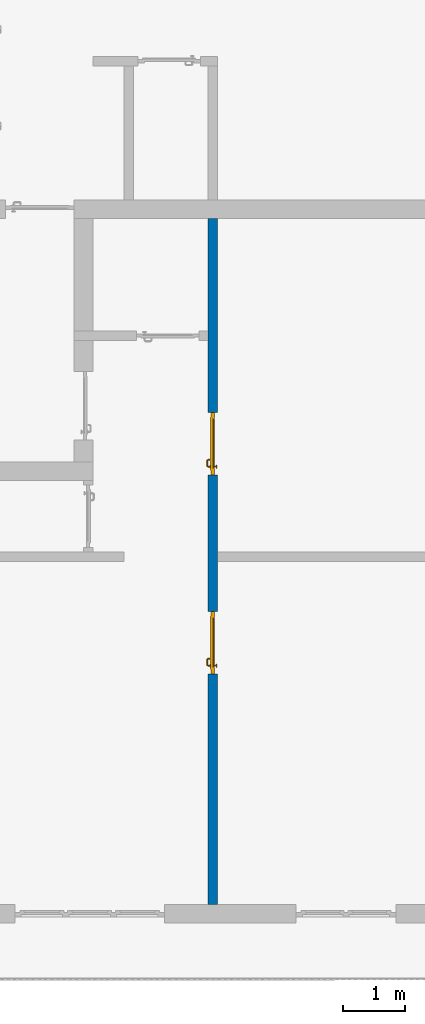
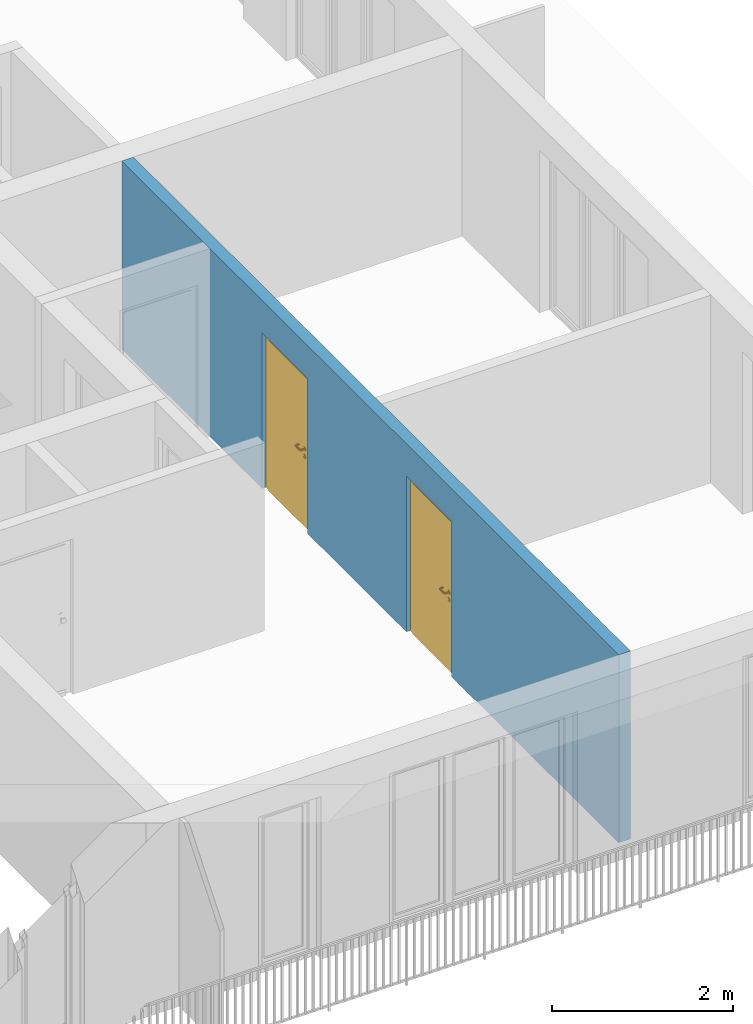
# One storey, part 19 of 54: 2 doors, 1 wall, 2 openings.
"""IFC4 building model written with IfcOpenShell, lengths in metres."""

from ifc_helpers import new_model, entity, si_unit, converted_unit, derived_unit, direction, frame, origin_with_axes, place, context, subcontext, project, spatial, polygons, source, transform, mapped, material, type_object, element, fill, save


model = new_model("IFC4")

# Units and contexts
model_context = context("Model", 3, precision=1e-05, world=origin_with_axes(), true_north=direction((0.0, 1.0)))
body_context = subcontext(model_context, "Body", "Model", "MODEL_VIEW")
ifc_project = project(units=[si_unit("LENGTHUNIT", "METRE"), si_unit("AREAUNIT", "SQUARE_METRE"), si_unit("VOLUMEUNIT", "CUBIC_METRE"), converted_unit("PLANEANGLEUNIT", "DEGREE", entity("IfcPlaneAngleMeasure", 0.0174532925199), si_unit("PLANEANGLEUNIT", "RADIAN"), dimensions=[0, 0, 0, 0, 0, 0, 0]), converted_unit("TIMEUNIT", "Year", entity("IfcTimeMeasure", 31556926.0), si_unit("TIMEUNIT", "SECOND"), dimensions=[0, 0, 1, 0, 0, 0, 0]), si_unit("MASSUNIT", "GRAM", prefix="KILO"), si_unit("THERMODYNAMICTEMPERATUREUNIT", "DEGREE_CELSIUS"), si_unit("LUMINOUSINTENSITYUNIT", "LUMEN"), si_unit("ENERGYUNIT", "JOULE", prefix="MEGA"), derived_unit("THERMALCONDUCTANCEUNIT", [(si_unit("POWERUNIT", "WATT"), 1), (si_unit("LENGTHUNIT", "METRE"), -1), (si_unit("THERMODYNAMICTEMPERATUREUNIT", "KELVIN"), -1)]), derived_unit("SPECIFICHEATCAPACITYUNIT", [(si_unit("ENERGYUNIT", "JOULE"), 1), (si_unit("MASSUNIT", "GRAM", prefix="KILO"), -1), (si_unit("THERMODYNAMICTEMPERATUREUNIT", "KELVIN"), -1)]), derived_unit("MASSDENSITYUNIT", [(si_unit("MASSUNIT", "GRAM", prefix="KILO"), 1), (si_unit("VOLUMEUNIT", "CUBIC_METRE"), -1)])], contexts=[model_context])

# Site, building, storey
site_placement = place(None, origin_with_axes())
site = spatial("IfcSite", under=ifc_project, at=site_placement, CompositionType="ELEMENT")
building_placement = place(site_placement, origin_with_axes())
building = spatial("IfcBuilding", under=site, at=building_placement, CompositionType="ELEMENT")
storey_placement = place(building_placement, frame((0.0, 0.0, 6.29), z_axis=(0.0, 0.0, 1.0), x_axis=(1.0, 0.0, 0.0)))
storey = spatial("IfcBuildingStorey", under=building, at=storey_placement, Name="2. Geschoss", CompositionType="ELEMENT", Elevation=6.29)

# Wall, openings, doors
ifc_material = material()
wall_type = type_object("IfcWallType", Name="150", PredefinedType="NOTDEFINED")
wall_placement = place(storey_placement, frame((4.6878006196, -9.92881223104, 0.0), z_axis=(0.0, 0.0, 1.0), x_axis=(0.0, 1.0, 0.0)))
wall = element("IfcWall", 1, at=wall_placement, inside=storey, type_object=wall_type, material=ifc_material, Name="Wand-002", PredefinedType="NOTDEFINED", context=body_context, shape_type="Tessellation", body=[
    polygons([(4.0, -0.15, 2.1), (4.0, 0.0, 2.1), (5.0, 0.0, 2.1), (5.0, -0.15, 2.1), (4.0, -0.1, 0.0), (4.0, 0.0, 0.0), (4.0, -0.15, 0.0), (0.3, 0.0, 0.0), (0.3, 0.0, 2.54), (11.3, 0.0, 2.54), (11.3, 0.0, 0.0), (8.1921181063, 0.0, 0.0), (8.1921181063, 0.0, 2.1), (7.1921181063, 0.0, 2.1), (7.1921181063, 0.0, 0.0), (5.0, 0.0, 0.0), (5.0, -0.1, 0.0), (5.0, -0.15, 0.0), (11.3, -0.15, 2.54), (0.3, -0.15, 2.54), (0.3, -0.15, 0.0), (7.1921181063, -0.15, 0.0), (7.1921181063, -0.15, 2.1), (8.1921181063, -0.15, 2.1), (8.1921181063, -0.15, 0.0), (11.3, -0.15, 0.0)], [[[1, 2, 3, 4]], [[5, 6, 2, 1, 7]], [[2, 6, 8, 9, 10, 11, 12, 13, 14, 15, 16, 3]], [[4, 3, 16, 17, 18]], [[19, 20, 21, 7, 1, 4, 18, 22, 23, 24, 25, 26]], [[6, 5, 7, 21, 8]], [[21, 20, 9, 8]], [[9, 20, 19, 10]], [[11, 10, 19, 26]], [[26, 25, 12, 11]], [[25, 24, 13, 12]], [[13, 24, 23, 14]], [[23, 22, 15, 14]], [[17, 16, 15, 22, 18]]], closed=True),
])
opening_1_placement = place(wall_placement, frame((7.6921181063, 0.0, 0.0), z_axis=(0.0, 0.0, 1.0), x_axis=(1.0, 0.0, 0.0)))
opening_1 = element("IfcOpeningElement", 2, at=opening_1_placement, cuts=wall, context=body_context, identifier="Reference", shape_type="Tessellation", body=[
    polygons([(0.5, -0.1, 0.0), (0.5, -0.1, 2.1), (0.5, -0.151, 2.1), (0.5, -0.151, 0.0), (0.5, 0.001, 0.0), (0.5, 0.001, 2.1), (-0.5, -0.1, 2.1), (-0.5, -0.151, 2.1), (-0.5, 0.001, 2.1), (-0.5, -0.151, 0.0), (-0.5, -0.1, 0.0), (-0.5, 0.001, 0.0)], [[[1, 2, 3, 4]], [[2, 1, 5, 6]], [[7, 8, 3, 2, 6, 9]], [[8, 10, 4, 3]], [[1, 4, 10, 11, 12, 5]], [[6, 5, 12, 9]], [[7, 11, 10, 8]], [[11, 7, 9, 12]]], closed=True),
])
opening_2_placement = place(wall_placement, frame((4.5, 0.0, 0.0), z_axis=(0.0, 0.0, 1.0), x_axis=(1.0, 0.0, 0.0)))
opening_2 = element("IfcOpeningElement", 3, at=opening_2_placement, cuts=wall, context=body_context, identifier="Reference", shape_type="Tessellation", body=[
    polygons([(0.5, -0.1, 0.0), (0.5, -0.1, 2.1), (0.5, -0.151, 2.1), (0.5, -0.151, 0.0), (0.5, 0.001, 0.0), (0.5, 0.001, 2.1), (-0.5, -0.1, 2.1), (-0.5, -0.151, 2.1), (-0.5, 0.001, 2.1), (-0.5, -0.151, 0.0), (-0.5, -0.1, 0.0), (-0.5, 0.001, 0.0)], [[[1, 2, 3, 4]], [[2, 1, 5, 6]], [[7, 8, 3, 2, 6, 9]], [[8, 10, 4, 3]], [[1, 4, 10, 11, 12, 5]], [[6, 5, 12, 9]], [[7, 11, 10, 8]], [[11, 7, 9, 12]]], closed=True),
])
door_type = type_object("IfcDoorType", Name="Eingang 01 1-Fl 26", OperationType="SINGLE_SWING_RIGHT", PredefinedType="DOOR")
shared_shape = source(origin_with_axes(), body_context, "Body", "Tessellation", [
    polygons([(0.5, -0.05, 0.0), (0.5, -0.03, 0.0), (0.5, -0.03, 2.1), (0.5, -0.05, 2.1), (0.4, -0.05, 0.0), (0.4, -0.03, 0.0), (0.4, -0.03, 2.0), (0.1301, -0.03, 2.0), (0.0001, -0.03, 2.0), (-0.4, -0.03, 2.0), (-0.4, -0.03, 0.0), (-0.5, -0.03, 0.0), (-0.5, -0.03, 2.1), (-0.5, -0.05, 2.1), (-0.5, -0.05, 0.0), (-0.4, -0.05, 0.0), (-0.4, -0.05, 2.0), (0.0001, -0.05, 2.0), (0.1301, -0.05, 2.0), (0.4, -0.05, 2.0)], [[[1, 2, 3, 4]], [[5, 6, 2, 1]], [[2, 6, 7, 8, 9, 10, 11, 12, 13, 3]], [[4, 3, 13, 14]], [[1, 4, 14, 15, 16, 17, 18, 19, 20, 5]], [[20, 7, 6, 5]], [[19, 8, 7, 20]], [[18, 9, 8, 19]], [[17, 10, 9, 18]], [[16, 11, 10, 17]], [[15, 12, 11, 16]], [[14, 13, 12, 15]]], closed=True),
    polygons([(0.5, -0.03, 0.0), (0.5, 0.0, 0.0), (0.5, 0.0, 2.1), (0.5, -0.03, 2.1), (0.43, -0.03, 0.0), (0.43, 0.0, 0.0), (0.43, 0.0, 2.03), (0.1001, 0.0, 2.03), (0.0301, 0.0, 2.03), (-0.43, 0.0, 2.03), (-0.43, 0.0, 0.0), (-0.5, 0.0, 0.0), (-0.5, 0.0, 2.1), (-0.5, -0.03, 2.1), (-0.5, -0.03, 0.0), (-0.43, -0.03, 0.0), (-0.43, -0.03, 2.03), (0.0301, -0.03, 2.03), (0.1001, -0.03, 2.03), (0.43, -0.03, 2.03)], [[[1, 2, 3, 4]], [[5, 6, 2, 1]], [[2, 6, 7, 8, 9, 10, 11, 12, 13, 3]], [[4, 3, 13, 14]], [[1, 4, 14, 15, 16, 17, 18, 19, 20, 5]], [[20, 7, 6, 5]], [[19, 8, 7, 20]], [[18, 9, 8, 19]], [[17, 10, 9, 18]], [[16, 11, 10, 17]], [[15, 12, 11, 16]], [[14, 13, 12, 15]]], closed=True),
    polygons([(0.43, 0.01, 0.0), (-0.43, 0.01, 0.0), (-0.43, 0.01, 2.03), (0.43, 0.01, 2.03), (0.43, -0.03, 0.0), (-0.43, -0.03, 0.0), (-0.43, -0.03, 2.03), (0.43, -0.03, 2.03)], [[[1, 2, 3, 4]], [[2, 1, 5, 6]], [[3, 2, 6, 7]], [[4, 3, 7, 8]], [[1, 4, 8, 5]], [[6, 5, 8, 7]]], closed=True),
    polygons([(0.395, -0.05, 0.0), (0.395, -0.05, 0.05), (-0.395, -0.05, 0.05), (-0.395, -0.05, 0.0), (0.395, -0.03, 0.0), (0.395, -0.03, 0.07), (0.395, -0.035, 0.07), (-0.395, -0.035, 0.07), (-0.395, -0.03, 0.07), (-0.395, -0.03, 0.0)], [[[1, 2, 3, 4]], [[1, 5, 6, 7, 2]], [[2, 7, 8, 3]], [[4, 3, 8, 9, 10]], [[5, 1, 4, 10]], [[6, 5, 10, 9]], [[7, 6, 9, 8]]], closed=True),
    polygons([(-0.3835, 0.02, 1.0733826859), (-0.3835, 0.0199, 1.0733826859), (-0.37, 0.0199, 1.077), (-0.37, 0.02, 1.077), (-0.393382685902, 0.02, 1.0635), (-0.393382685902, 0.0199, 1.0635), (-0.3835, 0.0101, 1.0733826859), (-0.37, 0.0101, 1.077), (-0.3565, 0.0199, 1.0733826859), (-0.3565, 0.02, 1.0733826859), (-0.346617314098, 0.02, 1.0635), (-0.343, 0.02, 1.05), (-0.346617314098, 0.02, 1.0365), (-0.3565, 0.02, 1.0266173141), (-0.37, 0.02, 1.023), (-0.3835, 0.02, 1.0266173141), (-0.393382685902, 0.02, 1.0365), (-0.397, 0.02, 1.05), (-0.397, 0.0199, 1.05), (-0.393382685902, 0.0101, 1.0635), (-0.3835, 0.01, 1.0733826859), (-0.37, 0.01, 1.077), (-0.3565, 0.0101, 1.0733826859), (-0.346617314098, 0.0199, 1.0635), (-0.343, 0.0199, 1.05), (-0.346617314098, 0.0199, 1.0365), (-0.3565, 0.0199, 1.0266173141), (-0.37, 0.0199, 1.023), (-0.3835, 0.0199, 1.0266173141), (-0.393382685902, 0.0199, 1.0365), (-0.397, 0.0101, 1.05), (-0.393382685902, 0.01, 1.0635), (-0.397, 0.01, 1.05), (-0.393382685902, 0.01, 1.0365), (-0.3835, 0.01, 1.0266173141), (-0.37, 0.01, 1.023), (-0.3565, 0.01, 1.0266173141), (-0.346617314098, 0.01, 1.0365), (-0.343, 0.01, 1.05), (-0.346617314098, 0.01, 1.0635), (-0.3565, 0.01, 1.0733826859), (-0.346617314098, 0.0101, 1.0635), (-0.343, 0.0101, 1.05), (-0.346617314098, 0.0101, 1.0365), (-0.3565, 0.0101, 1.0266173141), (-0.37, 0.0101, 1.023), (-0.3835, 0.0101, 1.0266173141), (-0.393382685902, 0.0101, 1.0365)], [[[1, 2, 3, 4]], [[5, 6, 2, 1]], [[2, 7, 8, 3]], [[4, 3, 9, 10]], [[4, 10, 11, 12, 13, 14, 15, 16, 17, 18, 5, 1]], [[18, 19, 6, 5]], [[6, 20, 7, 2]], [[7, 21, 22, 8]], [[3, 8, 23, 9]], [[10, 9, 24, 11]], [[11, 24, 25, 12]], [[12, 25, 26, 13]], [[13, 26, 27, 14]], [[14, 27, 28, 15]], [[15, 28, 29, 16]], [[16, 29, 30, 17]], [[17, 30, 19, 18]], [[19, 31, 20, 6]], [[20, 32, 21, 7]], [[22, 21, 32, 33, 34, 35, 36, 37, 38, 39, 40, 41]], [[8, 22, 41, 23]], [[9, 23, 42, 24]], [[24, 42, 43, 25]], [[25, 43, 44, 26]], [[26, 44, 45, 27]], [[27, 45, 46, 28]], [[28, 46, 47, 29]], [[29, 47, 48, 30]], [[30, 48, 31, 19]], [[31, 33, 32, 20]], [[48, 34, 33, 31]], [[47, 35, 34, 48]], [[46, 36, 35, 47]], [[45, 37, 36, 46]], [[44, 38, 37, 45]], [[43, 39, 38, 44]], [[42, 40, 39, 43]], [[23, 41, 40, 42]]], closed=True),
    polygons([(-0.362532169224, 0.019, 0.959692280177), (-0.365, 0.019, 0.9544), (-0.365, 0.019, 0.952886751346), (-0.347569942042, 0.019, 0.96295), (-0.35705, 0.019, 0.972430057958), (-0.363279754556, 0.019, 0.961639806549), (-0.362532169224, 0.02, 0.959692280177), (-0.365, 0.02, 0.9544), (-0.365, 0.02, 0.952886751346), (-0.365, 0.02, 0.95), (-0.365, 0.02, 0.947113248654), (-0.365, 0.02, 0.941339745962), (-0.365, 0.02, 0.9375), (-0.365, 0.019, 0.9375), (-0.365, 0.019, 0.941339745962), (-0.365, 0.019, 0.947113248654), (-0.365, 0.019, 0.95), (-0.3441, 0.019, 0.95), (-0.347483339502, 0.019, 0.963), (-0.357, 0.019, 0.972516660498), (-0.364624817685, 0.019, 0.965143815798), (-0.37, 0.019, 0.9759), (-0.37, 0.019, 0.967425445323), (-0.364624817685, 0.02, 0.965143815798), (-0.363279754556, 0.02, 0.961639806549), (-0.35655, 0.02, 0.973296083362), (-0.346703916638, 0.02, 0.96345), (-0.3431, 0.02, 0.95), (-0.346703916638, 0.02, 0.93655), (-0.35655, 0.02, 0.926703916638), (-0.37, 0.02, 0.9231), (-0.37, 0.02, 0.9325), (-0.366464466094, 0.02, 0.933964466094), (-0.366464466094, 0.019, 0.933964466094), (-0.35705, 0.019, 0.927569942042), (-0.37, 0.019, 0.9325), (-0.37, 0.019, 0.9241), (-0.347569942042, 0.019, 0.93705), (-0.344, 0.019, 0.95), (-0.347483339502, 0.0189, 0.963), (-0.357, 0.0189, 0.972516660498), (-0.37, 0.019, 0.976), (-0.375375182315, 0.019, 0.965143815798), (-0.38295, 0.019, 0.972430057958), (-0.376720245444, 0.019, 0.961639806549), (-0.37, 0.02, 0.967425445323), (-0.37, 0.02, 0.9769), (-0.346617314098, 0.02, 0.9635), (-0.3565, 0.02, 0.973382685902), (-0.343, 0.02, 0.95), (-0.346617314098, 0.02, 0.9365), (-0.3565, 0.02, 0.926617314098), (-0.38345, 0.02, 0.926703916638), (-0.375, 0.02, 0.941339745962), (-0.375, 0.02, 0.9375), (-0.373535533906, 0.02, 0.933964466094), (-0.37, 0.02, 0.923), (-0.373535533906, 0.019, 0.933964466094), (-0.375, 0.019, 0.9375), (-0.375, 0.019, 0.941339745962), (-0.38295, 0.019, 0.927569942042), (-0.37, 0.019, 0.924), (-0.357, 0.019, 0.927483339502), (-0.347483339502, 0.019, 0.937), (-0.344, 0.0189, 0.95), (-0.347483339502, 0.0101, 0.963), (-0.357, 0.0101, 0.972516660498), (-0.37, 0.0189, 0.976), (-0.383, 0.019, 0.972516660498), (-0.375375182315, 0.02, 0.965143815798), (-0.377467830776, 0.019, 0.959692280177), (-0.392430057958, 0.019, 0.96295), (-0.375, 0.019, 0.952886751346), (-0.375, 0.019, 0.9544), (-0.377467830776, 0.02, 0.959692280177), (-0.376720245444, 0.02, 0.961639806549), (-0.38345, 0.02, 0.973296083362), (-0.37, 0.02, 0.977), (-0.346617314098, 0.0199, 0.9635), (-0.3565, 0.0199, 0.973382685902), (-0.343, 0.0199, 0.95), (-0.346617314098, 0.0199, 0.9365), (-0.3565, 0.0199, 0.926617314098), (-0.393296083362, 0.02, 0.93655), (-0.375, 0.02, 0.947113248654), (-0.375, 0.02, 0.9544), (-0.375, 0.019, 0.95), (-0.375, 0.019, 0.947113248654), (-0.375, 0.02, 0.95), (-0.375, 0.02, 0.952886751346), (-0.3835, 0.02, 0.926617314098), (-0.37, 0.0199, 0.923), (-0.392430057958, 0.019, 0.93705), (-0.383, 0.019, 0.927483339502), (-0.37, 0.0189, 0.924), (-0.357, 0.0189, 0.927483339502), (-0.347483339502, 0.0189, 0.937), (-0.344, 0.0101, 0.95), (-0.347483339502, 0.01, 0.963), (-0.357, 0.01, 0.972516660498), (-0.37, 0.0101, 0.976), (-0.383, 0.0189, 0.972516660498), (-0.392516660498, 0.019, 0.963), (-0.3959, 0.019, 0.95), (-0.393296083362, 0.02, 0.96345), (-0.3835, 0.02, 0.973382685902), (-0.37, 0.0199, 0.977), (-0.346617314098, 0.0101, 0.9635), (-0.3565, 0.0101, 0.973382685902), (-0.343, 0.0101, 0.95), (-0.346617314098, 0.0101, 0.9365), (-0.3565, 0.0101, 0.926617314098), (-0.393382685902, 0.02, 0.9365), (-0.3969, 0.02, 0.95), (-0.3835, 0.0199, 0.926617314098), (-0.37, 0.0101, 0.923), (-0.392516660498, 0.019, 0.937), (-0.383, 0.0189, 0.927483339502), (-0.37, 0.0101, 0.924), (-0.357, 0.0101, 0.927483339502), (-0.347483339502, 0.0101, 0.937), (-0.344, 0.01, 0.95), (-0.347396736961, 0.01, 0.96305), (-0.35695, 0.01, 0.972603263039), (-0.37, 0.01, 0.976), (-0.383, 0.0101, 0.972516660498), (-0.392516660498, 0.0189, 0.963), (-0.396, 0.019, 0.95), (-0.393382685902, 0.02, 0.9635), (-0.3835, 0.0199, 0.973382685902), (-0.37, 0.0101, 0.977), (-0.346617314098, 0.01, 0.9635), (-0.3565, 0.01, 0.973382685902), (-0.343, 0.01, 0.95), (-0.346617314098, 0.01, 0.9365), (-0.3565, 0.01, 0.926617314098), (-0.397, 0.02, 0.95), (-0.393382685902, 0.0199, 0.9365), (-0.3835, 0.0101, 0.926617314098), (-0.37, 0.01, 0.923), (-0.392516660498, 0.0189, 0.937), (-0.383, 0.0101, 0.927483339502), (-0.37, 0.01, 0.924), (-0.357, 0.01, 0.927483339502), (-0.347483339502, 0.01, 0.937), (-0.3439, 0.01, 0.95), (-0.346703916638, 0.01, 0.96345), (-0.35655, 0.01, 0.973296083362), (-0.37, 0.01, 0.9761), (-0.383, 0.01, 0.972516660498), (-0.392516660498, 0.0101, 0.963), (-0.396, 0.0189, 0.95), (-0.393382685902, 0.0199, 0.9635), (-0.3835, 0.0101, 0.973382685902), (-0.37, 0.01, 0.977), (-0.3431, 0.01, 0.95), (-0.346703916638, 0.01, 0.93655), (-0.35655, 0.01, 0.926703916638), (-0.397, 0.0199, 0.95), (-0.393382685902, 0.0101, 0.9365), (-0.3835, 0.01, 0.926617314098), (-0.37, 0.01, 0.9231), (-0.392516660498, 0.0101, 0.937), (-0.383, 0.01, 0.927483339502), (-0.37, 0.01, 0.9239), (-0.35695, 0.01, 0.927396736961), (-0.347396736961, 0.01, 0.93695), (-0.37, 0.01, 0.9769), (-0.38305, 0.01, 0.972603263039), (-0.392516660498, 0.01, 0.963), (-0.396, 0.0101, 0.95), (-0.393382685902, 0.0101, 0.9635), (-0.3835, 0.01, 0.973382685902), (-0.397, 0.0101, 0.95), (-0.393382685902, 0.01, 0.9365), (-0.38345, 0.01, 0.926703916638), (-0.392516660498, 0.01, 0.937), (-0.38305, 0.01, 0.927396736961), (-0.38345, 0.01, 0.973296083362), (-0.392603263039, 0.01, 0.96305), (-0.396, 0.01, 0.95), (-0.393382685902, 0.01, 0.9635), (-0.397, 0.01, 0.95), (-0.393296083362, 0.01, 0.93655), (-0.392603263039, 0.01, 0.93695), (-0.393296083362, 0.01, 0.96345), (-0.3961, 0.01, 0.95), (-0.3969, 0.01, 0.95)], [[[1, 2, 3, 4, 5, 6]], [[2, 1, 7, 8]], [[2, 8, 9, 10, 11, 12, 13, 14, 15, 16, 17, 3]], [[17, 18, 4, 3]], [[4, 19, 20, 5]], [[21, 6, 5, 22, 23]], [[1, 6, 21, 24, 25, 7]], [[7, 25, 26, 27, 9, 8]], [[9, 27, 28, 10]], [[10, 28, 29, 11]], [[11, 29, 30, 12]], [[31, 32, 33, 13, 12, 30]], [[14, 13, 33, 34]], [[35, 15, 14, 34, 36, 37]], [[15, 35, 38, 16]], [[16, 38, 18, 17]], [[18, 39, 19, 4]], [[19, 40, 41, 20]], [[5, 20, 42, 22]], [[43, 23, 22, 44, 45]], [[21, 23, 46, 24]], [[24, 46, 47, 26, 25]], [[48, 27, 26, 49]], [[50, 28, 27, 48]], [[51, 29, 28, 50]], [[52, 30, 29, 51]], [[53, 54, 55, 56, 32, 31]], [[34, 33, 32, 36]], [[57, 31, 30, 52]], [[37, 36, 58, 59, 60, 61]], [[37, 62, 63, 35]], [[35, 63, 64, 38]], [[38, 64, 39, 18]], [[39, 65, 40, 19]], [[40, 66, 67, 41]], [[20, 41, 68, 42]], [[22, 42, 69, 44]], [[23, 43, 70, 46]], [[71, 45, 44, 72, 73, 74]], [[43, 45, 71, 75, 76, 70]], [[70, 76, 77, 47, 46]], [[49, 26, 47, 78]], [[79, 48, 49, 80]], [[81, 50, 48, 79]], [[82, 51, 50, 81]], [[83, 52, 51, 82]], [[54, 53, 84, 85]], [[86, 74, 73, 87, 88, 60, 59, 55, 54, 85, 89, 90]], [[58, 56, 55, 59]], [[36, 32, 56, 58]], [[91, 53, 31, 57]], [[92, 57, 52, 83]], [[88, 93, 61, 60]], [[61, 94, 62, 37]], [[62, 95, 96, 63]], [[63, 96, 97, 64]], [[64, 97, 65, 39]], [[65, 98, 66, 40]], [[66, 99, 100, 67]], [[41, 67, 101, 68]], [[42, 68, 102, 69]], [[44, 69, 103, 72]], [[73, 72, 104, 87]], [[71, 74, 86, 75]], [[75, 86, 90, 105, 77, 76]], [[78, 47, 77, 106]], [[80, 49, 78, 107]], [[108, 79, 80, 109]], [[110, 81, 79, 108]], [[111, 82, 81, 110]], [[112, 83, 82, 111]], [[113, 84, 53, 91]], [[85, 84, 114, 89]], [[87, 104, 93, 88]], [[89, 114, 105, 90]], [[115, 91, 57, 92]], [[116, 92, 83, 112]], [[93, 117, 94, 61]], [[94, 118, 95, 62]], [[95, 119, 120, 96]], [[96, 120, 121, 97]], [[97, 121, 98, 65]], [[98, 122, 99, 66]], [[99, 123, 124, 100]], [[67, 100, 125, 101]], [[68, 101, 126, 102]], [[69, 102, 127, 103]], [[72, 103, 128, 104]], [[106, 77, 105, 129]], [[107, 78, 106, 130]], [[109, 80, 107, 131]], [[132, 108, 109, 133]], [[134, 110, 108, 132]], [[135, 111, 110, 134]], [[136, 112, 111, 135]], [[137, 114, 84, 113]], [[138, 113, 91, 115]], [[104, 128, 117, 93]], [[129, 105, 114, 137]], [[139, 115, 92, 116]], [[140, 116, 112, 136]], [[117, 141, 118, 94]], [[118, 142, 119, 95]], [[119, 143, 144, 120]], [[120, 144, 145, 121]], [[121, 145, 122, 98]], [[122, 146, 123, 99]], [[123, 147, 148, 124]], [[100, 124, 149, 125]], [[101, 125, 150, 126]], [[102, 126, 151, 127]], [[103, 127, 152, 128]], [[130, 106, 129, 153]], [[131, 107, 130, 154]], [[133, 109, 131, 155]], [[147, 132, 133, 148]], [[156, 134, 132, 147]], [[157, 135, 134, 156]], [[158, 136, 135, 157]], [[159, 137, 113, 138]], [[160, 138, 115, 139]], [[128, 152, 141, 117]], [[153, 129, 137, 159]], [[161, 139, 116, 140]], [[162, 140, 136, 158]], [[141, 163, 142, 118]], [[142, 164, 143, 119]], [[143, 165, 166, 144]], [[144, 166, 167, 145]], [[145, 167, 146, 122]], [[146, 156, 147, 123]], [[124, 148, 168, 149]], [[125, 149, 169, 150]], [[126, 150, 170, 151]], [[127, 151, 171, 152]], [[154, 130, 153, 172]], [[155, 131, 154, 173]], [[148, 133, 155, 168]], [[167, 157, 156, 146]], [[166, 158, 157, 167]], [[174, 159, 138, 160]], [[175, 160, 139, 161]], [[152, 171, 163, 141]], [[172, 153, 159, 174]], [[176, 161, 140, 162]], [[165, 162, 158, 166]], [[163, 177, 164, 142]], [[164, 178, 165, 143]], [[149, 168, 179, 169]], [[150, 169, 180, 170]], [[151, 170, 181, 171]], [[173, 154, 172, 182]], [[168, 155, 173, 179]], [[183, 174, 160, 175]], [[184, 175, 161, 176]], [[171, 181, 177, 163]], [[182, 172, 174, 183]], [[178, 176, 162, 165]], [[177, 185, 178, 164]], [[169, 179, 186, 180]], [[170, 180, 187, 181]], [[179, 173, 182, 186]], [[188, 183, 175, 184]], [[185, 184, 176, 178]], [[181, 187, 185, 177]], [[186, 182, 183, 188]], [[180, 186, 188, 187]], [[187, 188, 184, 185]]], closed=True),
    polygons([(-0.38, 0.02, 1.05), (-0.38, 0.0509849140336, 1.05), (-0.377071067812, 0.050696439392, 1.04292893219), (-0.377071067812, 0.02, 1.04292893219), (-0.377071067812, 0.02, 1.05707106781), (-0.377071067812, 0.050696439392, 1.05707106781), (-0.378277987014, 0.0596420579258, 1.05), (-0.375518993221, 0.0584992452783, 1.04292893219), (-0.37, 0.05, 1.04), (-0.37, 0.02, 1.04), (-0.37, 0.02, 1.06), (-0.37, 0.05, 1.06), (-0.375518993221, 0.0584992452783, 1.05707106781), (-0.372816199938, 0.0678161999379, 1.05), (-0.370704557509, 0.0657045575088, 1.04292893219), (-0.368858192988, 0.0557402514855, 1.04), (-0.362928932188, 0.049303560608, 1.04292893219), (-0.362928932188, 0.02, 1.04292893219), (-0.362928932188, 0.02, 1.05707106781), (-0.362928932188, 0.049303560608, 1.05707106781), (-0.368858192988, 0.0557402514855, 1.06), (-0.370704557509, 0.0657045575088, 1.05707106781), (-0.364642057926, 0.0732779870137, 1.05), (-0.363499245278, 0.0705189932208, 1.04292893219), (-0.365606601718, 0.0606066017178, 1.04), (-0.362197392755, 0.0529812576926, 1.04292893219), (-0.36, 0.0490150859664, 1.05), (-0.36, 0.02, 1.05), (-0.362197392755, 0.0529812576926, 1.05707106781), (-0.365606601718, 0.0606066017178, 1.06), (-0.363499245278, 0.0705189932208, 1.05707106781), (-0.355984914034, 0.075, 1.05), (-0.355696439392, 0.0720710678119, 1.04292893219), (-0.360740251485, 0.0638581929877, 1.04), (-0.360508645927, 0.0555086459268, 1.04292893219), (-0.359438398962, 0.0518384450452, 1.05), (-0.360508645927, 0.0555086459268, 1.05707106781), (-0.360740251485, 0.0638581929877, 1.06), (-0.355696439392, 0.0720710678119, 1.05707106781), (-0.274015085966, 0.075, 1.05), (-0.274303560608, 0.0720710678119, 1.04292893219), (-0.355, 0.065, 1.04), (-0.357981257693, 0.0571973927545, 1.04292893219), (-0.358397003498, 0.0533970034977, 1.05), (-0.357981257693, 0.0571973927545, 1.05707106781), (-0.355, 0.065, 1.06), (-0.274303560608, 0.0720710678119, 1.05707106781), (-0.265357942074, 0.0732779870137, 1.05), (-0.266500754722, 0.0705189932208, 1.04292893219), (-0.275, 0.065, 1.04), (-0.354303560608, 0.0579289321881, 1.04292893219), (-0.356838445045, 0.0544383989617, 1.05), (-0.354303560608, 0.0579289321881, 1.05707106781), (-0.275, 0.065, 1.06), (-0.266500754722, 0.0705189932208, 1.05707106781), (-0.257183800062, 0.0678161999379, 1.05), (-0.259295442491, 0.0657045575088, 1.04292893219), (-0.269259748515, 0.0638581929877, 1.04), (-0.275696439392, 0.0579289321881, 1.04292893219), (-0.354015085966, 0.055, 1.05), (-0.275696439392, 0.0579289321881, 1.05707106781), (-0.269259748515, 0.0638581929877, 1.06), (-0.259295442491, 0.0657045575088, 1.05707106781), (-0.251722012986, 0.0596420579258, 1.05), (-0.254481006779, 0.0584992452783, 1.04292893219), (-0.264393398282, 0.0606066017178, 1.04), (-0.272018742307, 0.0571973927545, 1.04292893219), (-0.275984914034, 0.055, 1.05), (-0.272018742307, 0.0571973927545, 1.05707106781), (-0.264393398282, 0.0606066017178, 1.06), (-0.254481006779, 0.0584992452783, 1.05707106781), (-0.25, 0.0509849140336, 1.05), (-0.252928932188, 0.050696439392, 1.04292893219), (-0.261141807012, 0.0557402514855, 1.04), (-0.269491354073, 0.0555086459268, 1.04292893219), (-0.273161554955, 0.0544383989617, 1.05), (-0.269491354073, 0.0555086459268, 1.05707106781), (-0.261141807012, 0.0557402514855, 1.06), (-0.252928932188, 0.050696439392, 1.05707106781), (-0.25, 0.02, 1.05), (-0.252928932188, 0.02, 1.04292893219), (-0.26, 0.05, 1.04), (-0.267802607245, 0.0529812576926, 1.04292893219), (-0.271602996502, 0.0533970034977, 1.05), (-0.267802607245, 0.0529812576926, 1.05707106781), (-0.26, 0.05, 1.06), (-0.252928932188, 0.02, 1.05707106781), (-0.26, 0.02, 1.06), (-0.267071067812, 0.02, 1.05707106781), (-0.27, 0.02, 1.05), (-0.267071067812, 0.02, 1.04292893219), (-0.26, 0.02, 1.04), (-0.267071067812, 0.049303560608, 1.04292893219), (-0.270561601038, 0.0518384450452, 1.05), (-0.267071067812, 0.049303560608, 1.05707106781), (-0.27, 0.0490150859664, 1.05)], [[[1, 2, 3, 4]], [[5, 6, 2, 1]], [[2, 7, 8, 3]], [[4, 3, 9, 10]], [[11, 12, 6, 5]], [[6, 13, 7, 2]], [[7, 14, 15, 8]], [[3, 8, 16, 9]], [[10, 9, 17, 18]], [[19, 20, 12, 11]], [[12, 21, 13, 6]], [[13, 22, 14, 7]], [[14, 23, 24, 15]], [[8, 15, 25, 16]], [[9, 16, 26, 17]], [[18, 17, 27, 28]], [[28, 27, 20, 19]], [[20, 29, 21, 12]], [[21, 30, 22, 13]], [[22, 31, 23, 14]], [[23, 32, 33, 24]], [[15, 24, 34, 25]], [[16, 25, 35, 26]], [[17, 26, 36, 27]], [[27, 36, 29, 20]], [[29, 37, 30, 21]], [[30, 38, 31, 22]], [[31, 39, 32, 23]], [[32, 40, 41, 33]], [[24, 33, 42, 34]], [[25, 34, 43, 35]], [[26, 35, 44, 36]], [[36, 44, 37, 29]], [[37, 45, 38, 30]], [[38, 46, 39, 31]], [[39, 47, 40, 32]], [[40, 48, 49, 41]], [[33, 41, 50, 42]], [[34, 42, 51, 43]], [[35, 43, 52, 44]], [[44, 52, 45, 37]], [[45, 53, 46, 38]], [[46, 54, 47, 39]], [[47, 55, 48, 40]], [[48, 56, 57, 49]], [[41, 49, 58, 50]], [[42, 50, 59, 51]], [[43, 51, 60, 52]], [[52, 60, 53, 45]], [[53, 61, 54, 46]], [[54, 62, 55, 47]], [[55, 63, 56, 48]], [[56, 64, 65, 57]], [[49, 57, 66, 58]], [[50, 58, 67, 59]], [[51, 59, 68, 60]], [[60, 68, 61, 53]], [[61, 69, 62, 54]], [[62, 70, 63, 55]], [[63, 71, 64, 56]], [[64, 72, 73, 65]], [[57, 65, 74, 66]], [[58, 66, 75, 67]], [[59, 67, 76, 68]], [[68, 76, 69, 61]], [[69, 77, 70, 62]], [[70, 78, 71, 63]], [[71, 79, 72, 64]], [[72, 80, 81, 73]], [[65, 73, 82, 74]], [[66, 74, 83, 75]], [[67, 75, 84, 76]], [[76, 84, 77, 69]], [[77, 85, 78, 70]], [[78, 86, 79, 71]], [[79, 87, 80, 72]], [[80, 87, 88, 89, 90, 91, 92, 81]], [[73, 81, 92, 82]], [[74, 82, 93, 83]], [[75, 83, 94, 84]], [[84, 94, 85, 77]], [[85, 95, 86, 78]], [[86, 88, 87, 79]], [[95, 89, 88, 86]], [[96, 90, 89, 95]], [[93, 91, 90, 96]], [[82, 92, 91, 93]], [[83, 93, 96, 94]], [[94, 96, 95, 85]]], closed=False),
    polygons([(-0.364696699141, -0.035, 1.04469669914), (-0.37, -0.035, 1.0425), (-0.375303300859, -0.035, 1.04469669914), (-0.3775, -0.035, 1.05), (-0.375303300859, -0.035, 1.05530330086), (-0.37, -0.035, 1.0575), (-0.364696699141, -0.035, 1.05530330086), (-0.3625, -0.035, 1.05), (-0.364696699141, -0.075, 1.04469669914), (-0.37, -0.075, 1.0425), (-0.375303300859, -0.075, 1.04469669914), (-0.3775, -0.075, 1.05), (-0.375303300859, -0.075, 1.05530330086), (-0.37, -0.075, 1.0575), (-0.364696699141, -0.075, 1.05530330086), (-0.3625, -0.075, 1.05)], [[[1, 2, 3, 4, 5, 6, 7, 8]], [[2, 1, 9, 10]], [[3, 2, 10, 11]], [[4, 3, 11, 12]], [[5, 4, 12, 13]], [[6, 5, 13, 14]], [[7, 6, 14, 15]], [[8, 7, 15, 16]], [[1, 8, 16, 9]], [[9, 16, 15, 14, 13, 12, 11, 10]]], closed=True),
    polygons([(-0.395, -0.03, 0.975), (-0.393096988313, -0.03, 0.965432914191), (-0.393096988313, -0.035, 0.965432914191), (-0.395, -0.035, 0.975), (-0.395, -0.03, 1.1), (-0.393096988313, -0.03, 1.10956708581), (-0.38767766953, -0.03, 1.11767766953), (-0.379567085809, -0.03, 1.12309698831), (-0.37, -0.03, 1.125), (-0.360432914191, -0.03, 1.12309698831), (-0.35232233047, -0.03, 1.11767766953), (-0.346903011687, -0.03, 1.10956708581), (-0.345, -0.03, 1.1), (-0.345, -0.03, 0.975), (-0.346903011687, -0.03, 0.965432914191), (-0.35232233047, -0.03, 0.95732233047), (-0.360432914191, -0.03, 0.951903011687), (-0.37, -0.03, 0.95), (-0.379567085809, -0.03, 0.951903011687), (-0.38767766953, -0.03, 0.95732233047), (-0.38767766953, -0.035, 0.95732233047), (-0.379567085809, -0.035, 0.951903011687), (-0.37, -0.035, 0.95), (-0.360432914191, -0.035, 0.951903011687), (-0.35232233047, -0.035, 0.95732233047), (-0.346903011687, -0.035, 0.965432914191), (-0.345, -0.035, 0.975), (-0.345, -0.035, 1.1), (-0.346903011687, -0.035, 1.10956708581), (-0.35232233047, -0.035, 1.11767766953), (-0.360432914191, -0.035, 1.12309698831), (-0.37, -0.035, 1.125), (-0.379567085809, -0.035, 1.12309698831), (-0.38767766953, -0.035, 1.11767766953), (-0.393096988313, -0.035, 1.10956708581), (-0.395, -0.035, 1.1)], [[[1, 2, 3, 4]], [[1, 5, 6, 7, 8, 9, 10, 11, 12, 13, 14, 15, 16, 17, 18, 19, 20, 2]], [[2, 20, 21, 3]], [[4, 3, 21, 22, 23, 24, 25, 26, 27, 28, 29, 30, 31, 32, 33, 34, 35, 36]], [[5, 1, 4, 36]], [[6, 5, 36, 35]], [[7, 6, 35, 34]], [[8, 7, 34, 33]], [[9, 8, 33, 32]], [[10, 9, 32, 31]], [[11, 10, 31, 30]], [[12, 11, 30, 29]], [[13, 12, 29, 28]], [[14, 13, 28, 27]], [[15, 14, 27, 26]], [[16, 15, 26, 25]], [[17, 16, 25, 24]], [[18, 17, 24, 23]], [[19, 18, 23, 22]], [[20, 19, 22, 21]]], closed=True),
    polygons([(-0.39, -0.075, 1.08), (-0.395, -0.075, 1.07866025404), (-0.395, -0.09, 1.07866025404), (-0.39, -0.09, 1.08), (-0.35, -0.075, 1.08), (-0.345, -0.075, 1.07866025404), (-0.341339745962, -0.075, 1.075), (-0.34, -0.075, 1.07), (-0.34, -0.075, 1.03), (-0.341339745962, -0.075, 1.025), (-0.345, -0.075, 1.02133974596), (-0.35, -0.075, 1.02), (-0.39, -0.075, 1.02), (-0.395, -0.075, 1.02133974596), (-0.398660254038, -0.075, 1.025), (-0.4, -0.075, 1.03), (-0.4, -0.075, 1.07), (-0.398660254038, -0.075, 1.075), (-0.398660254038, -0.09, 1.075), (-0.4, -0.09, 1.07), (-0.4, -0.09, 1.03), (-0.398660254038, -0.09, 1.025), (-0.395, -0.09, 1.02133974596), (-0.39, -0.09, 1.02), (-0.35, -0.09, 1.02), (-0.345, -0.09, 1.02133974596), (-0.341339745962, -0.09, 1.025), (-0.34, -0.09, 1.03), (-0.34, -0.09, 1.07), (-0.341339745962, -0.09, 1.075), (-0.345, -0.09, 1.07866025404), (-0.35, -0.09, 1.08)], [[[1, 2, 3, 4]], [[1, 5, 6, 7, 8, 9, 10, 11, 12, 13, 14, 15, 16, 17, 18, 2]], [[2, 18, 19, 3]], [[4, 3, 19, 20, 21, 22, 23, 24, 25, 26, 27, 28, 29, 30, 31, 32]], [[5, 1, 4, 32]], [[6, 5, 32, 31]], [[7, 6, 31, 30]], [[8, 7, 30, 29]], [[9, 8, 29, 28]], [[10, 9, 28, 27]], [[11, 10, 27, 26]], [[12, 11, 26, 25]], [[13, 12, 25, 24]], [[14, 13, 24, 23]], [[15, 14, 23, 22]], [[16, 15, 22, 21]], [[17, 16, 21, 20]], [[18, 17, 20, 19]]], closed=True),
])
door_1_placement = place(opening_1_placement, frame((-0.4, 0.0, 0.0), z_axis=(0.0, 0.0, 1.0), x_axis=(1.0, 0.0, 0.0)))
door_1 = element("IfcDoor", 4, at=door_1_placement, inside=storey, type_object=door_type, OverallHeight=2.1, OverallWidth=1.0, PredefinedType="DOOR", context=body_context, shape_type="MappedRepresentation", body=[
    mapped(shared_shape, transform((0.4, -0.05, 0.0))),
])
fill(opening_1, door_1)
door_2_placement = place(opening_2_placement, frame((-0.4, 0.0, 0.0), z_axis=(0.0, 0.0, 1.0), x_axis=(1.0, 0.0, 0.0)))
door_2 = element("IfcDoor", 5, at=door_2_placement, inside=storey, type_object=door_type, OverallHeight=2.1, OverallWidth=1.0, PredefinedType="DOOR", context=body_context, shape_type="MappedRepresentation", body=[
    mapped(shared_shape, transform((0.4, -0.05, 0.0))),
])
fill(opening_2, door_2)

save(model, "model.ifc")
